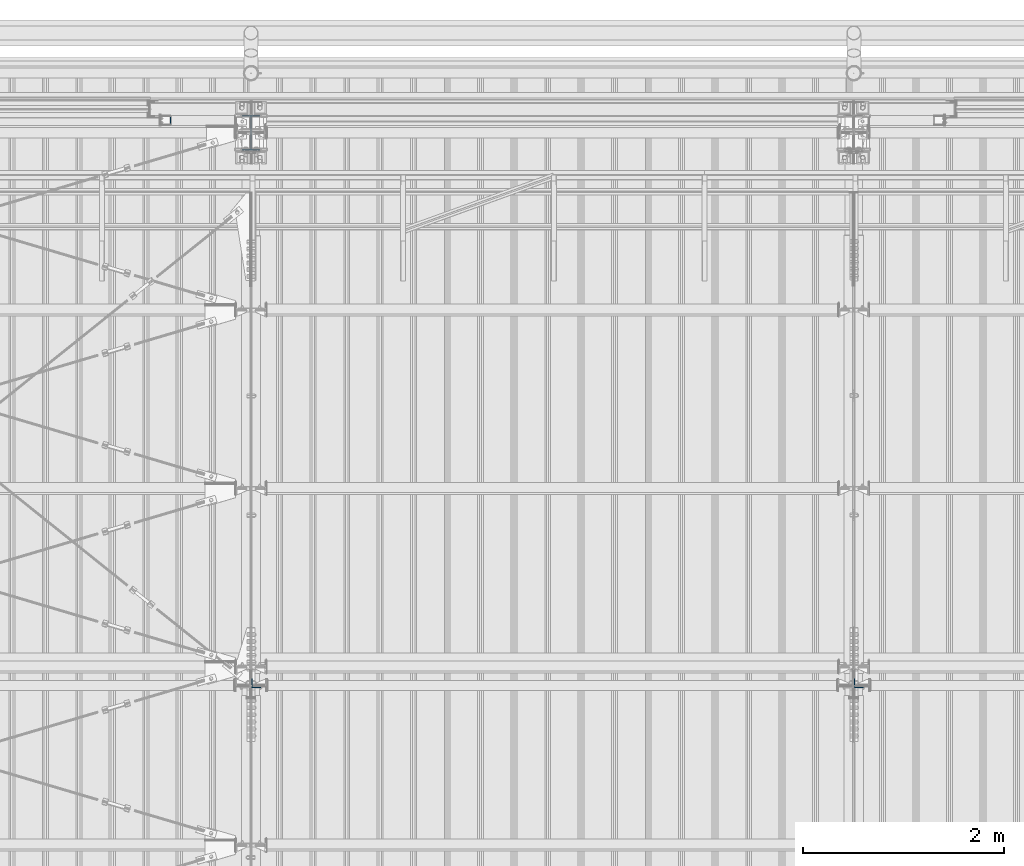
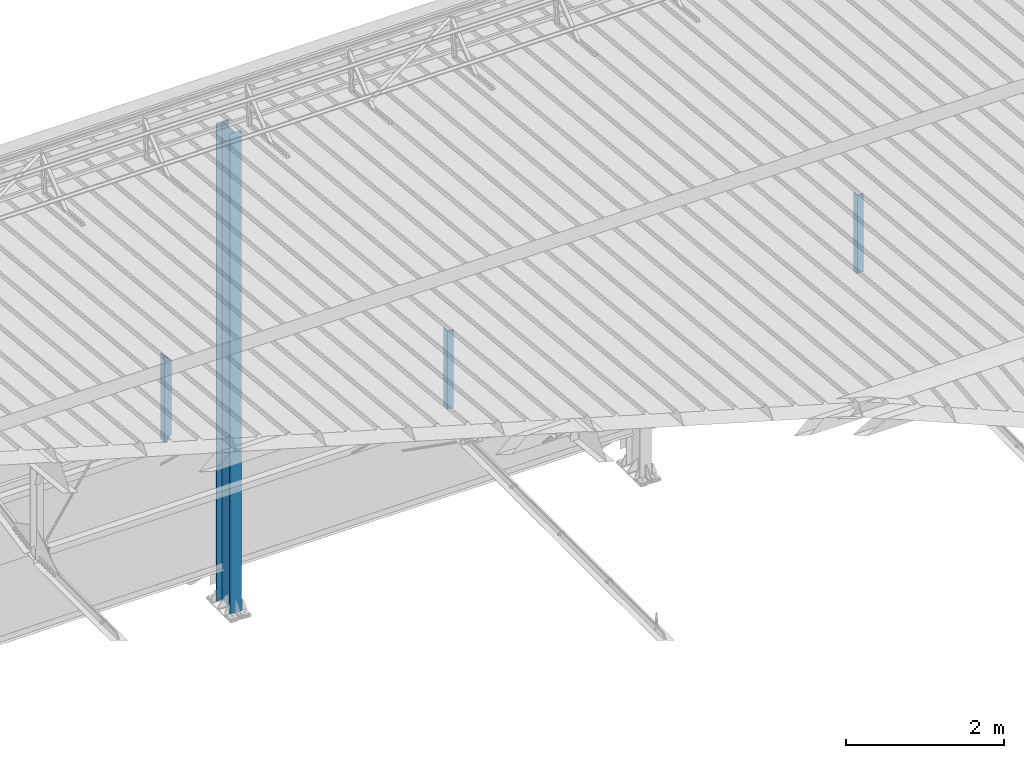
# One storey, part 231 of 709: 4 columns, 4 elements without a shape of their own.
"""IFC4 building model written with IfcOpenShell, lengths in millimetres."""

from ifc_helpers import new_model, si_unit, direction, frame, origin_with_axes, place, context, subcontext, project, spatial, polygons, material, element, aggregate, save


model = new_model("IFC4")

# Units and contexts
model_context = context("Model", 3, precision=0.2, world=origin_with_axes(), true_north=direction((0.0, 1.0)))
body_context = subcontext(model_context, "Body", "Model", "MODEL_VIEW")
ifc_project = project(units=[si_unit("LENGTHUNIT", "METRE", prefix="MILLI"), si_unit("AREAUNIT", "SQUARE_METRE"), si_unit("VOLUMEUNIT", "CUBIC_METRE"), si_unit("MASSUNIT", "GRAM", prefix="KILO"), si_unit("TIMEUNIT", "SECOND"), si_unit("PLANEANGLEUNIT", "RADIAN"), si_unit("SOLIDANGLEUNIT", "STERADIAN"), si_unit("THERMODYNAMICTEMPERATUREUNIT", "DEGREE_CELSIUS"), si_unit("LUMINOUSINTENSITYUNIT", "LUMEN")], contexts=[model_context])

# Site, building, storey
site_placement = place(None, origin_with_axes())
site = spatial("IfcSite", under=ifc_project, at=site_placement, CompositionType="ELEMENT")
building_placement = place(site_placement, origin_with_axes())
building = spatial("IfcBuilding", under=site, at=building_placement, Name="Undefined", CompositionType="ELEMENT")
storey_placement = place(building_placement, origin_with_axes())
storey = spatial("IfcBuildingStorey", under=building, at=storey_placement, Name="Undefined", CompositionType="ELEMENT", Elevation=0.0)

# Assembly, column
assembly_1_placement = place(storey_placement, frame((10000.0, 21827.0, -200.0), z_axis=(-1.0, 0.0, 0.0), x_axis=(0.0, 0.0, 1.0)))
assembly_1 = element("IfcElementAssembly", 1, at=assembly_1_placement, inside=storey)
ifc_material_1 = material(Name="C355-5", Category="STEEL")
column_1_placement = place(assembly_1_placement, origin_with_axes())
column_1 = element("IfcColumn", 2, at=column_1_placement, material=ifc_material_1, ObjectType="413", context=body_context, shape_type="Tessellation", body=[
    polygons([(25.0, -173.0, -87.0), (25.0, -164.0, -87.0), (7454.62297, -164.0, -87.0), (7455.52297, -173.0, -87.0), (25.0, -164.0, -3.0), (7454.62297, -164.0, -3.0), (25.0, 164.0, -3.0), (7421.82297, 164.0, -3.0), (25.0, 164.0, -87.0), (7421.82297, 164.0, -87.0), (25.0, 173.0, -87.0), (7420.92297, 173.0, -87.0), (25.0, 173.0, 87.0), (7420.92297, 173.0, 87.0), (25.0, 164.0, 87.0), (7421.82297, 164.0, 87.0), (25.0, 164.0, 3.0), (7421.82297, 164.0, 3.0), (25.0, -164.0, 3.0), (7454.62297, -164.0, 3.0), (25.0, -164.0, 87.0), (7454.62297, -164.0, 87.0), (25.0, -173.0, 87.0), (7455.52297, -173.0, 87.0)], [[[1, 2, 3, 4]], [[2, 5, 6, 3]], [[5, 7, 8, 6]], [[7, 9, 10, 8]], [[9, 11, 12, 10]], [[11, 13, 14, 12]], [[13, 15, 16, 14]], [[15, 17, 18, 16]], [[17, 19, 20, 18]], [[19, 21, 22, 20]], [[21, 23, 24, 22]], [[23, 1, 4, 24]], [[6, 8, 10, 12, 14, 16, 18, 20, 22, 24, 4, 3]], [[23, 21, 19, 17, 15, 13, 11, 9, 7, 5, 2, 1]]], closed=True),
])
aggregate(assembly_1, [column_1])

assembly_2_placement = place(storey_placement, frame((10051.0, 16347.7, 6024.30002), z_axis=(0.0, 1.0, 0.0), x_axis=(0.0, 0.0, 1.0)))
assembly_2 = element("IfcElementAssembly", 3, at=assembly_2_placement, inside=storey)
ifc_material_2 = material(Name="C345-5", Category="STEEL")
column_2_placement = place(assembly_2_placement, origin_with_axes())
column_2 = element("IfcColumn", 4, at=column_2_placement, material=ifc_material_2, ObjectType="436", context=body_context, shape_type="Tessellation", body=[
    polygons([(185.7, -45.0, -45.0), (185.7, 45.0, -45.0), (1399.4109, 45.0, -45.0), (1399.4109, -45.0, -45.0), (185.7, 45.0, -39.0), (1399.4109, 45.0, -39.0), (185.7, -39.0, -39.0), (1399.4109, -39.0, -39.0), (185.7, -39.0, 45.0), (1399.4109, -39.0, 45.0), (185.7, -45.0, 45.0), (1399.4109, -45.0, 45.0)], [[[1, 2, 3, 4]], [[2, 5, 6, 3]], [[5, 7, 8, 6]], [[7, 9, 10, 8]], [[9, 11, 12, 10]], [[11, 1, 4, 12]], [[6, 8, 10, 12, 4, 3]], [[11, 9, 7, 5, 2, 1]]], closed=True),
])
aggregate(assembly_2, [column_2])

assembly_3_placement = place(storey_placement, frame((16051.0, 16347.7, 6024.30002), z_axis=(0.0, 1.0, 0.0), x_axis=(0.0, 0.0, 1.0)))
assembly_3 = element("IfcElementAssembly", 5, at=assembly_3_placement, inside=storey)
column_3_placement = place(assembly_3_placement, origin_with_axes())
column_3 = element("IfcColumn", 6, at=column_3_placement, material=ifc_material_2, ObjectType="436", context=body_context, shape_type="Tessellation", body=[
    polygons([(185.7, -45.0, -45.0), (185.7, 45.0, -45.0), (1399.4109, 45.0, -45.0), (1399.4109, -45.0, -45.0), (185.7, 45.0, -39.0), (1399.4109, 45.0, -39.0), (185.7, -39.0, -39.0), (1399.4109, -39.0, -39.0), (185.7, -39.0, 45.0), (1399.4109, -39.0, 45.0), (185.7, -45.0, 45.0), (1399.4109, -45.0, 45.0)], [[[1, 2, 3, 4]], [[2, 5, 6, 3]], [[5, 7, 8, 6]], [[7, 9, 10, 8]], [[9, 11, 12, 10]], [[11, 1, 4, 12]], [[6, 8, 10, 12, 4, 3]], [[11, 9, 7, 5, 2, 1]]], closed=True),
])
aggregate(assembly_3, [column_3])

assembly_4_placement = place(storey_placement, frame((9150.0, 21950.0, 2600.0), z_axis=(-1.0, 0.0, 0.0), x_axis=(0.0, 0.0, 1.0)))
assembly_4 = element("IfcElementAssembly", 7, at=assembly_4_placement, inside=storey)
ifc_material_3 = material(Name="C355", Category="STEEL")
column_4_placement = place(assembly_4_placement, origin_with_axes())
column_4 = element("IfcColumn", 8, at=column_4_placement, material=ifc_material_3, ObjectType="493", context=body_context, shape_type="Tessellation", body=[
    polygons([(10.0, -50.0, 50.0), (110.0, -50.0, -50.0), (1260.0, -50.0, -50.0), (1360.0, -50.0, 50.0), (10.0, 50.0, 50.0), (1360.0, 50.0, 50.0), (110.0, 50.0, -50.0), (1260.0, 50.0, -50.0), (13.0, -47.0, 47.0), (13.0, 47.0, 47.0), (1357.0, 47.0, 47.0), (1357.0, -47.0, 47.0), (107.0, -47.0, -47.0), (1263.0, -47.0, -47.0), (107.0, 47.0, -47.0), (1263.0, 47.0, -47.0)], [[[1, 2, 3, 4]], [[5, 1, 4, 6]], [[7, 5, 6, 8]], [[2, 7, 8, 3]], [[1, 5, 7, 2], [9, 13, 15, 10]], [[9, 10, 11, 12]], [[13, 9, 12, 14]], [[15, 13, 14, 16]], [[10, 15, 16, 11]], [[3, 8, 6, 4], [14, 12, 11, 16]]], closed=True),
])
aggregate(assembly_4, [column_4])

save(model, "model.ifc")
